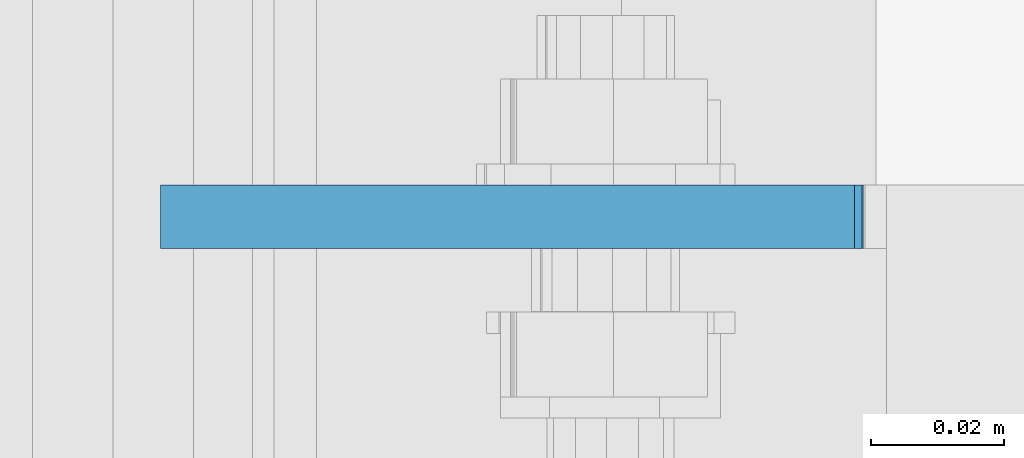
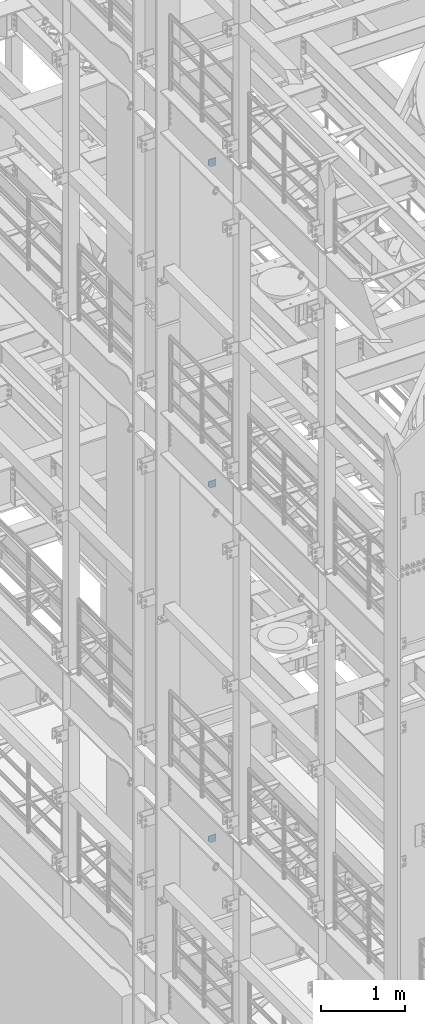
# One storey, part 1543 of 1876: 3 plates, 3 elements without a shape of their own.
"""IFC2X3 building model written with IfcOpenShell, lengths in millimetres."""

from ifc_helpers import new_model, si_unit, frame, origin_with_axes, place, context, subcontext, project, spatial, faceted_brep, material, type_object, element, aggregate, save


model = new_model("IFC2X3")

# Units and contexts
model_context = context("Model", 3, precision=1e-05, world=origin_with_axes())
body_context = subcontext(model_context, "Body", "Model", "MODEL_VIEW")
ifc_project = project(units=[si_unit("LENGTHUNIT", "METRE", prefix="MILLI"), si_unit("AREAUNIT", "SQUARE_METRE"), si_unit("VOLUMEUNIT", "CUBIC_METRE"), si_unit("MASSUNIT", "GRAM", prefix="KILO"), si_unit("TIMEUNIT", "SECOND"), si_unit("PLANEANGLEUNIT", "RADIAN"), si_unit("SOLIDANGLEUNIT", "STERADIAN"), si_unit("THERMODYNAMICTEMPERATUREUNIT", "DEGREE_CELSIUS"), si_unit("LUMINOUSINTENSITYUNIT", "LUMEN")], contexts=[model_context])

# Site, building, storey
site_placement = place(None, origin_with_axes())
site = spatial("IfcSite", under=ifc_project, at=site_placement, CompositionType="ELEMENT")
building_placement = place(site_placement, origin_with_axes())
building = spatial("IfcBuilding", under=site, at=building_placement, Name="Undefined", CompositionType="ELEMENT")
storey_placement = place(building_placement, origin_with_axes())
storey = spatial("IfcBuildingStorey", under=building, at=storey_placement, Name="Undefined", CompositionType="ELEMENT", Elevation=0.0)

# Assembly, plate
assembly_1_placement = place(storey_placement, origin_with_axes())
assembly_1 = element("IfcElementAssembly", 1, at=assembly_1_placement, inside=storey, Name="BEAM", AssemblyPlace="NOTDEFINED", PredefinedType="RIGID_FRAME")
ifc_material = material(Name="STEEL/A36")
plate_type_1 = type_object("IfcPlateType", PredefinedType="NOTDEFINED")
plate_1_placement = place(assembly_1_placement, frame((7.14374663773437, 300.037499999994, 12816.9742795602), z_axis=(0.0, 0.0, -1.0), x_axis=(1.0, 0.0, 0.0)))
plate_1 = element("IfcPlate", 2, at=plate_1_placement, type_object=plate_type_1, material=ifc_material, Name="PLATE", context=body_context, shape_type="Brep", body=[
    faceted_brep([(0.0, -4.76249999999982, 0.0), (3.36263383360347e-06, -4.76249999999999, 72.5242767333984), (3.36263383360347e-06, 4.76249999999999, 72.5242767333984), (0.0, 4.76249999999982, 0.0), (31.7500038146972, -4.76249999999999, 104.274276733398), (31.7500038146972, 4.76249999999999, 104.274276733398), (105.092643737793, -4.76249999999999, 104.274276733398), (105.092643737793, 4.76249999999999, 104.274276733398), (105.092643737793, -4.76249999999999, 0.0), (105.092643737793, 4.76249999999999, 0.0)], [[[0, 1, 2, 3]], [[1, 4, 5, 2]], [[4, 6, 7, 5]], [[6, 8, 9, 7]], [[8, 0, 3, 9]], [[5, 7, 9, 3, 2]], [[8, 6, 4, 1, 0]]]),
])
aggregate(assembly_1, [plate_1])

assembly_2_placement = place(storey_placement, origin_with_axes())
assembly_2 = element("IfcElementAssembly", 3, at=assembly_2_placement, inside=storey, Name="BEAM", AssemblyPlace="NOTDEFINED", PredefinedType="RIGID_FRAME")
plate_2_placement = place(assembly_2_placement, frame((111.128498160899, 300.037500000001, 17386.3), z_axis=(-1.0, 0.0, 0.0), x_axis=(0.0, 0.0, 1.0)))
plate_2 = element("IfcPlate", 4, at=plate_2_placement, type_object=plate_type_1, material=ifc_material, Name="PLATE", context=body_context, shape_type="Brep", body=[
    faceted_brep([(0.0, -4.76249999999982, 0.0), (0.0, -4.76249999999982, 72.234748840332), (0.0, 4.76249999999982, 72.234748840332), (0.0, 4.76249999999982, 0.0), (31.75, -4.76249999999982, 103.984748840332), (31.75, 4.76249999999982, 103.984748840332), (111.653274536133, -4.76249999999982, 103.984748840332), (111.653274536133, 4.76249999999982, 103.984748840332), (111.653274536133, -4.76249999999982, 0.0), (111.653274536133, 4.76249999999982, 0.0)], [[[0, 1, 2, 3]], [[1, 4, 5, 2]], [[4, 6, 7, 5]], [[6, 8, 9, 7]], [[8, 0, 3, 9]], [[5, 7, 9, 3, 2]], [[8, 6, 4, 1, 0]]]),
])
aggregate(assembly_2, [plate_2])

assembly_3_placement = place(storey_placement, origin_with_axes())
assembly_3 = element("IfcElementAssembly", 5, at=assembly_3_placement, inside=storey, Name="BEAM", AssemblyPlace="NOTDEFINED", PredefinedType="RIGID_FRAME")
plate_type_2 = type_object("IfcPlateType", PredefinedType="NOTDEFINED")
plate_3_placement = place(assembly_3_placement, frame((7.14375, 300.037499999999, 7556.5), z_axis=(0.0, 0.0, 1.0), x_axis=(1.0, 0.0, 0.0)))
plate_3 = element("IfcPlate", 6, at=plate_3_placement, type_object=plate_type_2, material=ifc_material, Name="PLATE", context=body_context, shape_type="Brep", body=[
    faceted_brep([(-9.76996261670138e-14, -4.76250000000073, 31.75), (0.0, -4.76249999999999, 103.486999511719), (0.0, 4.76249999999999, 103.486999511719), (-9.76996261670138e-14, 4.76250000000073, 31.75), (105.307250976562, -4.76249999999982, 103.486999511719), (105.307250976562, 4.76249999999982, 103.486999511719), (105.307250976562, -4.76249999999999, 0.0), (105.307250976562, 4.76249999999999, 0.0), (31.75, -4.76250000000073, 0.0), (31.75, 4.76250000000073, 0.0)], [[[0, 1, 2, 3]], [[1, 4, 5, 2]], [[4, 6, 7, 5]], [[6, 8, 9, 7]], [[8, 0, 3, 9]], [[5, 7, 9, 3, 2]], [[8, 6, 4, 1, 0]]]),
])
aggregate(assembly_3, [plate_3])

save(model, "model.ifc")
